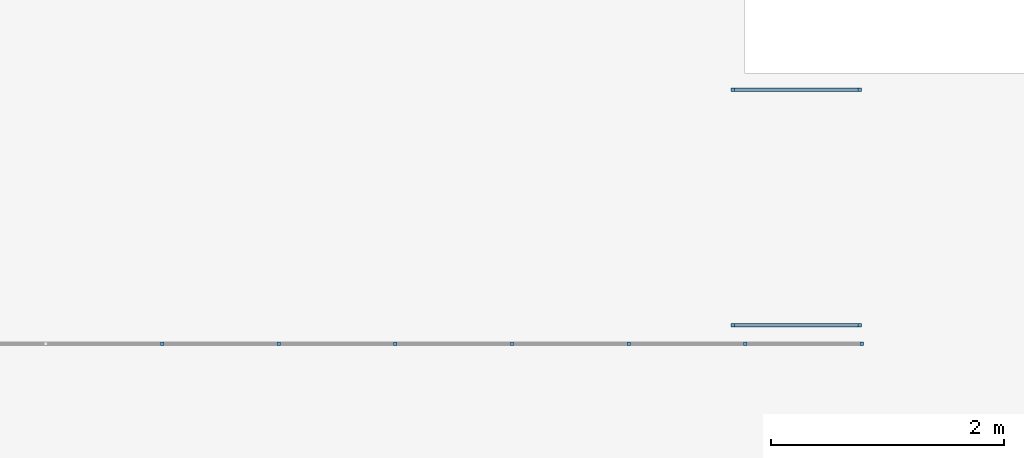
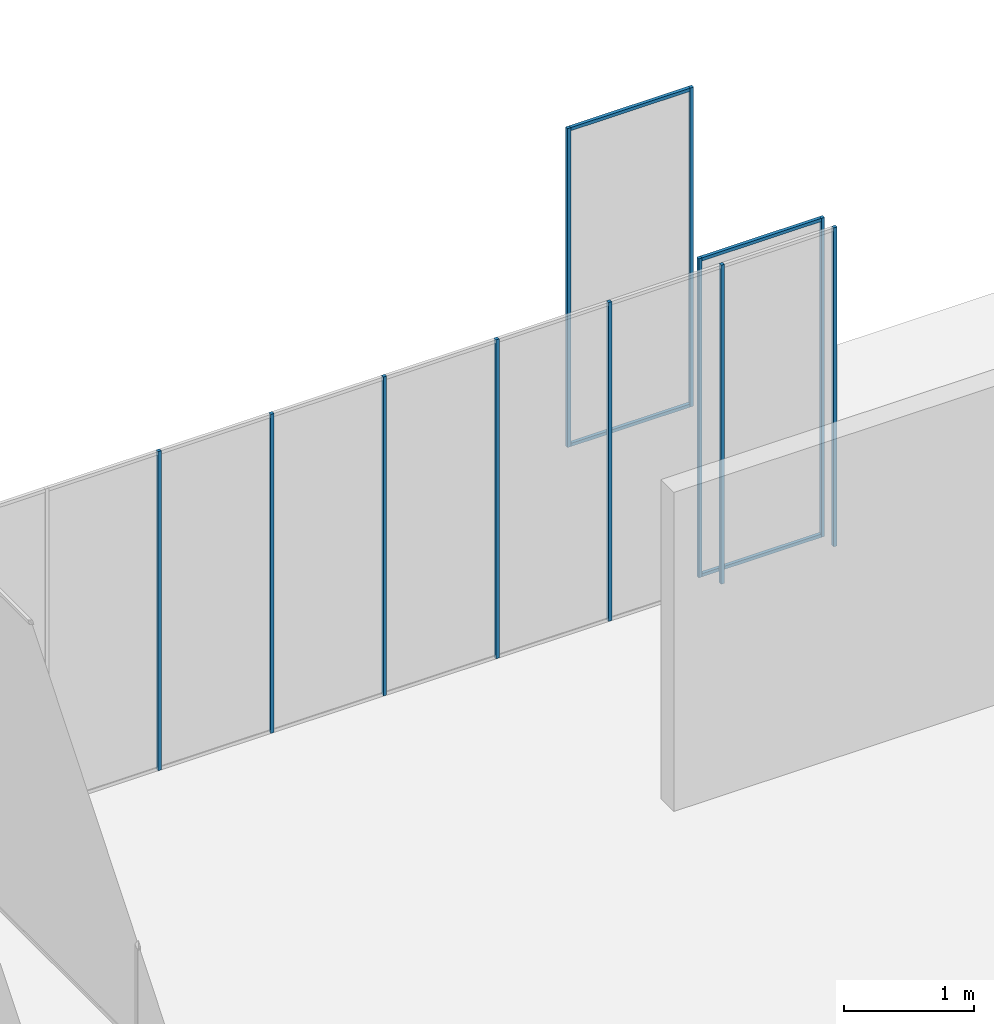
# One storey, part 5 of 8: 15 members, 3 elements without a shape of their own.
"""IFC2X3 building model written with IfcOpenShell, lengths in millimetres."""

from ifc_helpers import new_model, entity, si_unit, converted_unit, direction, frame, frame_2d, origin, place, context, subcontext, project, spatial, rectangle, extrude, element, aggregate, save


model = new_model("IFC2X3")

# Units and contexts
model_context = context("Model", 3, precision=1e-06, world=origin(), true_north=direction((2.0, 6.12303176911189e-17, 1.0)))
context_of_model = context(None, 3, precision=1e-06, world=origin(), true_north=direction((2.0, 6.12303176911189e-17, 1.0)))
body_context = subcontext(model_context, "Body", "Model", "MODEL_VIEW")
ifc_project = project(units=[si_unit("LENGTHUNIT", "METRE", prefix="MILLI"), si_unit("AREAUNIT", "SQUARE_METRE", prefix="MILLI"), si_unit("VOLUMEUNIT", "CUBIC_METRE", prefix="MILLI"), converted_unit("PLANEANGLEUNIT", "DEGREE", entity("IfcRatioMeasure", 0.0174532925199433), si_unit("PLANEANGLEUNIT", "RADIAN"), dimensions=[0, 0, 0, 0, 0, 0, 0]), si_unit("TIMEUNIT", "SECOND")], contexts=[model_context, context_of_model])

# Site, building, storey
site_placement = place(None, origin())
site = spatial("IfcSite", under=ifc_project, at=site_placement, CompositionType="ELEMENT")
building_placement = place(site_placement, origin())
building = spatial("IfcBuilding", under=site, at=building_placement, CompositionType="ELEMENT")
storey_placement = place(building_placement, frame((0.0, 0.0, 1500.0)))
storey = spatial("IfcBuildingStorey", under=building, at=storey_placement, Name="Level 1", CompositionType="ELEMENT", Elevation=1500.0)

# Curtain wall, members
curtain_wall_1_placement = place(storey_placement, origin())
curtain_wall_1 = element("IfcCurtainWall", 1, at=curtain_wall_1_placement, inside=storey, Name="Curtain Wall:Curtain Wall", ObjectType="Curtain Wall:Curtain Wall:334")
member_1_placement = place(storey_placement, origin())
member_1 = element("IfcMember", 2, at=member_1_placement, Name="Curtain Wall:Curtain Wall:8490", ObjectType="Curtain Wall:Curtain Wall:8490", context=body_context, shape_type="SweptSolid", body=[
    extrude(rectangle(XDim=30.0000000000002, YDim=30.0000000000008, at=frame_2d((2.70894418008538e-13, 5.41788836017076e-13), x_axis=(1.0, 0.0))), frame((7998.5, 2575.0, 0.0), z_axis=(0.0, 0.0, 1.0), x_axis=(0.0, -1.0, 0.0)), (0.0, 0.0, 1.0), 3000.0),
])
member_2_placement = place(storey_placement, origin())
member_2 = element("IfcMember", 3, at=member_2_placement, Name="Curtain Wall:Curtain Wall:8490", ObjectType="Curtain Wall:Curtain Wall:8490", context=body_context, shape_type="SweptSolid", body=[
    extrude(rectangle(XDim=30.0000000000002, YDim=30.0000000000008, at=frame_2d((2.70894418008538e-13, -5.41788836017076e-13), x_axis=(1.0, 0.0))), frame((9000.0, 2575.0, 0.0), z_axis=(0.0, 0.0, 1.0), x_axis=(0.0, -1.0, 0.0)), (0.0, 0.0, 1.0), 3000.0),
])
member_3_placement = place(storey_placement, origin())
member_3 = element("IfcMember", 4, at=member_3_placement, Name="Curtain Wall:Curtain Wall:8490", ObjectType="Curtain Wall:Curtain Wall:8490", context=body_context, shape_type="SweptSolid", body=[
    extrude(rectangle(XDim=30.0000000000002, YDim=29.9999999999997, at=frame_2d((2.70894418008538e-13, 1.08268949361445e-12), x_axis=(1.0, 0.0))), frame((10001.5, 2575.0, 0.0), z_axis=(0.0, 0.0, 1.0), x_axis=(0.0, -1.0, 0.0)), (0.0, 0.0, 1.0), 3000.0),
])
member_4_placement = place(storey_placement, origin())
member_4 = element("IfcMember", 5, at=member_4_placement, Name="Curtain Wall:Curtain Wall:8490", ObjectType="Curtain Wall:Curtain Wall:8490", context=body_context, shape_type="SweptSolid", body=[
    extrude(rectangle(XDim=30.0000000000002, YDim=29.9999999999997, at=frame_2d((2.70894418008538e-13, 1.08268949361445e-12), x_axis=(1.0, 0.0))), frame((11003.0, 2575.0, 0.0), z_axis=(0.0, 0.0, 1.0), x_axis=(0.0, -1.0, 0.0)), (0.0, 0.0, 1.0), 3000.0),
])
member_5_placement = place(storey_placement, origin())
member_5 = element("IfcMember", 6, at=member_5_placement, Name="Curtain Wall:Curtain Wall:8490", ObjectType="Curtain Wall:Curtain Wall:8490", context=body_context, shape_type="SweptSolid", body=[
    extrude(rectangle(XDim=30.0000000000002, YDim=29.9999999999997, at=frame_2d((2.70894418008538e-13, -1.08268949361445e-12), x_axis=(1.0, 0.0))), frame((12004.5, 2575.0, 0.0), z_axis=(0.0, 0.0, 1.0), x_axis=(0.0, -1.0, 0.0)), (0.0, 0.0, 1.0), 3000.0),
])
member_6_placement = place(storey_placement, origin())
member_6 = element("IfcMember", 7, at=member_6_placement, Name="Curtain Wall:Curtain Wall:8490", ObjectType="Curtain Wall:Curtain Wall:8490", context=body_context, shape_type="SweptSolid", body=[
    extrude(rectangle(XDim=30.0000000000002, YDim=29.9999999999997, at=frame_2d((2.70894418008538e-13, 1.08268949361445e-12), x_axis=(1.0, 0.0))), frame((13006.0, 2575.0, 0.0), z_axis=(0.0, 0.0, 1.0), x_axis=(0.0, -1.0, 0.0)), (0.0, 0.0, 1.0), 3000.0),
])
member_7_placement = place(storey_placement, origin())
member_7 = element("IfcMember", 8, at=member_7_placement, Name="Curtain Wall:Curtain Wall:8490", ObjectType="Curtain Wall:Curtain Wall:8490", context=body_context, shape_type="SweptSolid", body=[
    extrude(rectangle(XDim=29.9999999999997, YDim=30.0000000000002, at=frame_2d((-1.08268949361445e-12, 2.70894418008538e-13), x_axis=(1.0, 0.0))), frame((14007.5, 2575.0, 0.0), z_axis=(0.0, 0.0, 1.0), x_axis=(-1.0, 0.0, 0.0)), (0.0, 0.0, 1.0), 3000.0),
])
aggregate(curtain_wall_1, [member_1, member_2, member_3, member_4, member_5, member_6, member_7])

curtain_wall_2_placement = place(storey_placement, origin())
curtain_wall_2 = element("IfcCurtainWall", 9, at=curtain_wall_2_placement, inside=storey, Name="Curtain Wall:Curtain Wall Zero Grid lines", ObjectType="Curtain Wall:Curtain Wall Zero Grid lines")
member_8_placement = place(storey_placement, origin())
member_8 = element("IfcMember", 10, at=member_8_placement, Name="Curtain Wall:Curtain Wall Zero Grid lines:8490", ObjectType="Curtain Wall:Curtain Wall Zero Grid lines:8490", context=body_context, shape_type="SweptSolid", body=[
    extrude(rectangle(XDim=1060.0, YDim=30.0000000000002, at=frame_2d((1.08002495835535e-12, 2.70894418008538e-13), x_axis=(1.0, 0.0))), frame((13445.0, 4755.0, 0.0)), (0.0, 0.0, 1.0), 29.9999999999999),
])
member_9_placement = place(storey_placement, origin())
member_9 = element("IfcMember", 11, at=member_9_placement, Name="Curtain Wall:Curtain Wall Zero Grid lines:8490", ObjectType="Curtain Wall:Curtain Wall Zero Grid lines:8490", context=body_context, shape_type="SweptSolid", body=[
    extrude(rectangle(XDim=30.0000000000002, YDim=29.9999999999997, at=frame_2d((-2.70894418008538e-13, -1.08268949361445e-12), x_axis=(1.0, 0.0))), frame((13990.0, 4755.0, 0.0), z_axis=(0.0, 0.0, 1.0), x_axis=(0.0, 1.0, 0.0)), (0.0, 0.0, 1.0), 3000.0),
])
member_10_placement = place(storey_placement, origin())
member_10 = element("IfcMember", 12, at=member_10_placement, Name="Curtain Wall:Curtain Wall Zero Grid lines:8490", ObjectType="Curtain Wall:Curtain Wall Zero Grid lines:8490", context=body_context, shape_type="SweptSolid", body=[
    extrude(rectangle(XDim=29.9999999999997, YDim=30.0000000000002, at=frame_2d((-1.08268949361445e-12, 2.70894418008538e-13), x_axis=(1.0, 0.0))), frame((12900.0, 4755.0, 0.0)), (0.0, 0.0, 1.0), 3000.0),
])
member_11_placement = place(storey_placement, origin())
member_11 = element("IfcMember", 13, at=member_11_placement, Name="Curtain Wall:Curtain Wall Zero Grid lines:8490", ObjectType="Curtain Wall:Curtain Wall Zero Grid lines:8490", context=body_context, shape_type="SweptSolid", body=[
    extrude(rectangle(XDim=1060.0, YDim=30.0000000000002, at=frame_2d((-1.08002495835535e-12, 0.0), x_axis=(1.0, 0.0))), frame((13445.0, 4755.0, 2970.0), z_axis=(0.0, 0.0, 1.0), x_axis=(-1.0, 0.0, 0.0)), (0.0, 0.0, 1.0), 30.0000000000002),
])
aggregate(curtain_wall_2, [member_8, member_9, member_10, member_11])

curtain_wall_3_placement = place(storey_placement, origin())
curtain_wall_3 = element("IfcCurtainWall", 14, at=curtain_wall_3_placement, inside=storey, Name="Curtain Wall:Curtain Wall Zero Grid lines", ObjectType="Curtain Wall:Curtain Wall Zero Grid lines")
member_12_placement = place(storey_placement, origin())
member_12 = element("IfcMember", 15, at=member_12_placement, Name="Curtain Wall:Curtain Wall Zero Grid lines:8490", ObjectType="Curtain Wall:Curtain Wall Zero Grid lines:8490", context=body_context, shape_type="SweptSolid", body=[
    extrude(rectangle(XDim=1060.0, YDim=30.0000000000002, at=frame_2d((-1.08002495835535e-12, 2.70894418008538e-13), x_axis=(1.0, 0.0))), frame((13445.0, 2735.0, 0.0)), (0.0, 0.0, 1.0), 29.9999999999999),
])
member_13_placement = place(storey_placement, origin())
member_13 = element("IfcMember", 16, at=member_13_placement, Name="Curtain Wall:Curtain Wall Zero Grid lines:8490", ObjectType="Curtain Wall:Curtain Wall Zero Grid lines:8490", context=body_context, shape_type="SweptSolid", body=[
    extrude(rectangle(XDim=30.0000000000002, YDim=29.9999999999997, at=frame_2d((-2.70894418008538e-13, -1.08268949361445e-12), x_axis=(1.0, 0.0))), frame((13990.0, 2735.0, 0.0), z_axis=(0.0, 0.0, 1.0), x_axis=(0.0, 1.0, 0.0)), (0.0, 0.0, 1.0), 3000.0),
])
member_14_placement = place(storey_placement, origin())
member_14 = element("IfcMember", 17, at=member_14_placement, Name="Curtain Wall:Curtain Wall Zero Grid lines:8490", ObjectType="Curtain Wall:Curtain Wall Zero Grid lines:8490", context=body_context, shape_type="SweptSolid", body=[
    extrude(rectangle(XDim=29.9999999999997, YDim=30.0000000000002, at=frame_2d((1.08268949361445e-12, 2.70894418008538e-13), x_axis=(1.0, 0.0))), frame((12900.0, 2735.0, 0.0)), (0.0, 0.0, 1.0), 3000.0),
])
member_15_placement = place(storey_placement, origin())
member_15 = element("IfcMember", 18, at=member_15_placement, Name="Curtain Wall:Curtain Wall Zero Grid lines:8490", ObjectType="Curtain Wall:Curtain Wall Zero Grid lines:8490", context=body_context, shape_type="SweptSolid", body=[
    extrude(rectangle(XDim=1060.0, YDim=30.0000000000002, at=frame_2d((-1.08002495835535e-12, 0.0), x_axis=(1.0, 0.0))), frame((13445.0, 2735.0, 2970.0), z_axis=(0.0, 0.0, 1.0), x_axis=(-1.0, 0.0, 0.0)), (0.0, 0.0, 1.0), 30.0000000000002),
])
aggregate(curtain_wall_3, [member_12, member_13, member_14, member_15])

save(model, "model.ifc")
